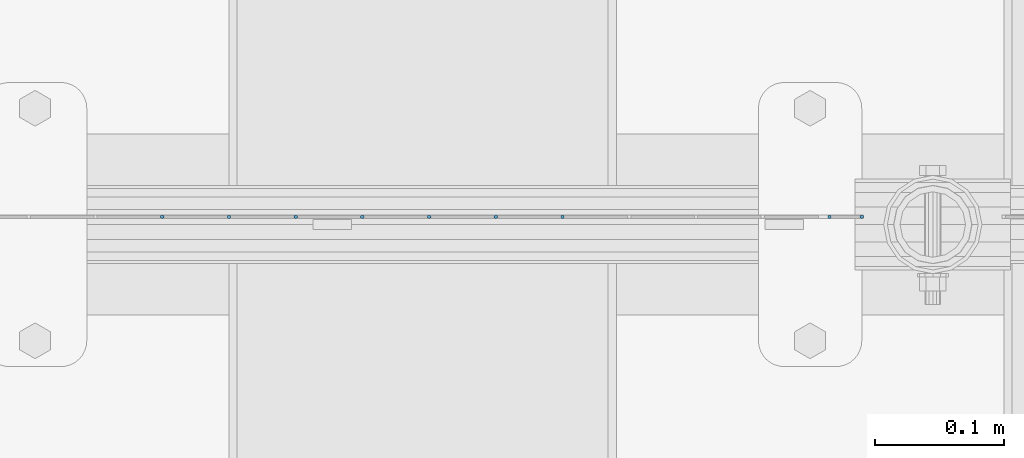
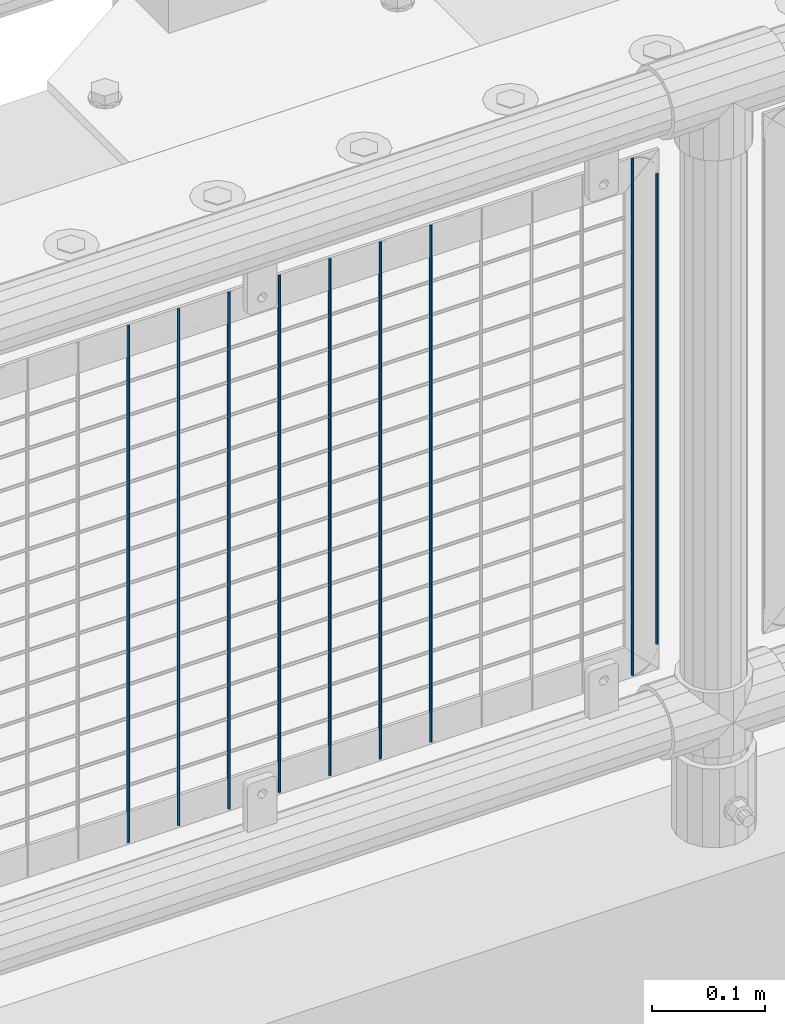
# One storey, part 64 of 193: 9 columns.
"""IFC2X3 building model written with IfcOpenShell, lengths in millimetres."""

from ifc_helpers import new_model, si_unit, frame, origin_with_axes, place, context, subcontext, project, spatial, faceted_brep, material, type_object, element, save


model = new_model("IFC2X3")

# Units and contexts
model_context = context("Model", 3, precision=1e-05, world=origin_with_axes())
body_context = subcontext(model_context, "Body", "Model", "MODEL_VIEW")
ifc_project = project(units=[si_unit("LENGTHUNIT", "METRE", prefix="MILLI"), si_unit("AREAUNIT", "SQUARE_METRE"), si_unit("VOLUMEUNIT", "CUBIC_METRE"), si_unit("MASSUNIT", "GRAM", prefix="KILO"), si_unit("TIMEUNIT", "SECOND"), si_unit("PLANEANGLEUNIT", "RADIAN"), si_unit("SOLIDANGLEUNIT", "STERADIAN"), si_unit("THERMODYNAMICTEMPERATUREUNIT", "DEGREE_CELSIUS"), si_unit("LUMINOUSINTENSITYUNIT", "LUMEN")], contexts=[model_context])

# Site, building, storey
site_placement = place(None, origin_with_axes())
site = spatial("IfcSite", under=ifc_project, at=site_placement, CompositionType="ELEMENT")
building_placement = place(site_placement, origin_with_axes())
building = spatial("IfcBuilding", under=site, at=building_placement, Name="Standard", CompositionType="ELEMENT")
storey_placement = place(building_placement, origin_with_axes())
storey = spatial("IfcBuildingStorey", under=building, at=storey_placement, Name="Undefined", CompositionType="ELEMENT", Elevation=0.0)

# Columns
ifc_material = material(Name="Misc_Undefined")
column_type = type_object("IfcColumnType", Name="D3", PredefinedType="NOTDEFINED")
for number, where, z_axis, x_axis in (
    (1, (-37141.625, 28670.5, 353.02), (-1.0, 0.0, 0.0), (0.0, 0.0, 1.0)),
    (2, (-37193.28, 28670.5, 353.02), (-1.0, 0.0, 0.0), (0.0, 0.0, 1.0)),
    (3, (-37244.935, 28670.5, 353.02), (-1.0, 0.0, 0.0), (0.0, 0.0, 1.0)),
    (4, (-37296.59, 28670.5, 353.02), (-1.0, 0.0, 0.0), (0.0, 0.0, 1.0)),
    (5, (-37348.245, 28670.5, 353.02), (-1.0, 0.0, 0.0), (0.0, 0.0, 1.0)),
    (6, (-37399.9, 28670.5, 353.02), (-1.0, 0.0, 0.0), (0.0, 0.0, 1.0)),
    (7, (-37451.555, 28670.5, 353.02), (-1.0, 0.0, 0.0), (0.0, 0.0, 1.0)),
    (8, (-36935.005, 28670.5, 353.02), (-1.0, 0.0, 0.0), (0.0, 0.0, 1.0)),
):
    element("IfcColumn", number, at=place(storey_placement, frame(where, z_axis=z_axis, x_axis=x_axis)), inside=storey, type_object=column_type, material=ifc_material, ObjectType="D3", context=body_context, shape_type="Brep", body=[
        faceted_brep([(0.0, -1.49999999999636, 3.63797880709171e-12), (0.0, -0.75, -1.29903810567669), (560.0, -0.75, -1.29903810567703), (560.0, -1.5, 0.0), (0.0, 0.75, -1.29903810567669), (560.0, 0.75, -1.29903810567703), (0.0, 1.50000000000364, 7.27595761418343e-12), (560.0, 1.5, 0.0), (0.0, 0.75, 1.29903810567669), (560.0, 0.75, 1.29903810567703), (0.0, -0.75, 1.29903810567669), (560.0, -0.75, 1.29903810567703)], [[[0, 1, 2, 3]], [[1, 4, 5, 2]], [[4, 6, 7, 5]], [[6, 8, 9, 7]], [[8, 10, 11, 9]], [[10, 0, 3, 11]], [[5, 7, 9, 11, 3, 2]], [[10, 8, 6, 4, 1, 0]]]),
    ])
column_placement = place(storey_placement, frame((-36910.0, 28670.5, 378.02), z_axis=(-1.0, 0.0, 0.0), x_axis=(0.0, 0.0, 1.0)))
element("IfcColumn", 9, at=column_placement, inside=storey, type_object=column_type, material=ifc_material, ObjectType="D3", context=body_context, shape_type="Brep", body=[
    faceted_brep([(0.0, -1.49999999999636, 3.63797880709171e-12), (0.0, -0.75, -1.29903810567669), (510.0, -0.75, -1.29903810567703), (510.0, -1.5, 0.0), (0.0, 0.75, -1.29903810567669), (510.0, 0.75, -1.29903810567703), (0.0, 1.50000000000364, 7.27595761418343e-12), (510.0, 1.5, 0.0), (0.0, 0.75, 1.29903810567669), (510.0, 0.75, 1.29903810567703), (0.0, -0.75, 1.29903810567669), (510.0, -0.75, 1.29903810567703)], [[[0, 1, 2, 3]], [[1, 4, 5, 2]], [[4, 6, 7, 5]], [[6, 8, 9, 7]], [[8, 10, 11, 9]], [[10, 0, 3, 11]], [[5, 7, 9, 11, 3, 2]], [[10, 8, 6, 4, 1, 0]]]),
])

save(model, "model.ifc")
